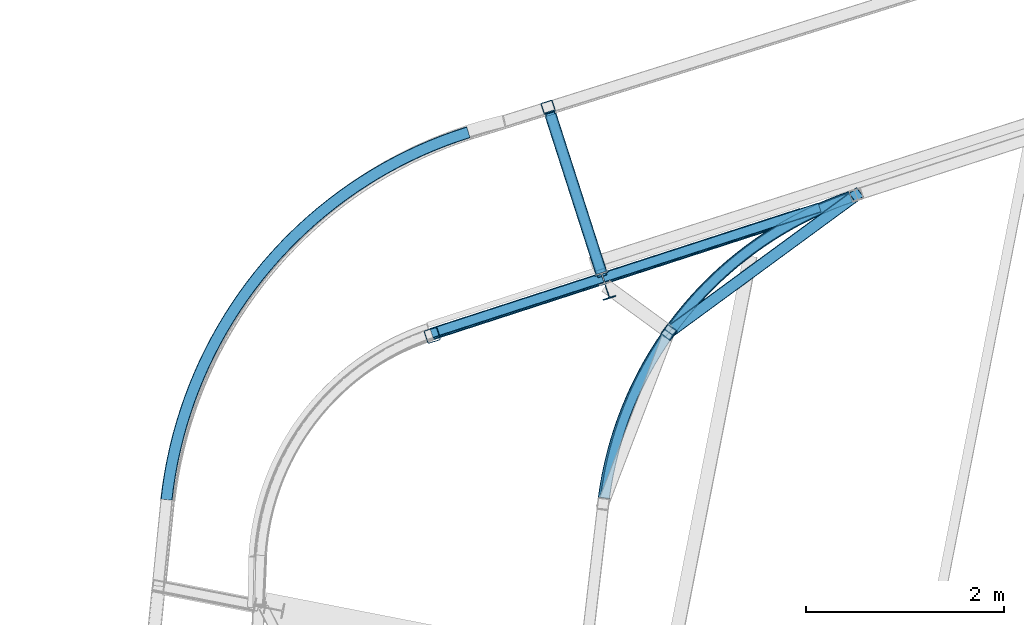
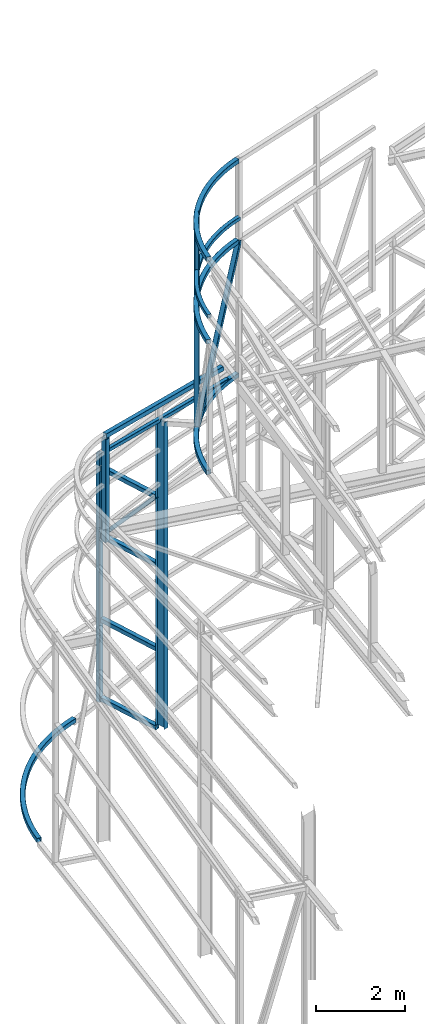
# One storey, part 79 of 215: 16 beams, 2 members, 18 elements without a shape of their own.
"""IFC2X3 building model written with IfcOpenShell, lengths in millimetres."""

from ifc_helpers import new_model, entity, si_unit, frame, origin_with_axes, origin_2d_with_axis, place, context, subcontext, project, spatial, hollow_rectangle, i_section, extrude, clip, halfspace, material, type_object, element, aggregate, save


model = new_model("IFC2X3")

# Units and contexts
model_context = context("Model", 3, precision=1e-05, world=origin_with_axes())
body_context = subcontext(model_context, "Body", "Model", "MODEL_VIEW")
ifc_project = project(units=[si_unit("LENGTHUNIT", "METRE", prefix="MILLI"), si_unit("AREAUNIT", "SQUARE_METRE"), si_unit("VOLUMEUNIT", "CUBIC_METRE"), si_unit("MASSUNIT", "GRAM", prefix="KILO"), si_unit("TIMEUNIT", "SECOND"), si_unit("PLANEANGLEUNIT", "RADIAN"), si_unit("SOLIDANGLEUNIT", "STERADIAN"), si_unit("THERMODYNAMICTEMPERATUREUNIT", "DEGREE_CELSIUS"), si_unit("LUMINOUSINTENSITYUNIT", "LUMEN")], contexts=[model_context])

# Site, building, storey
site_placement = place(None, origin_with_axes())
site = spatial("IfcSite", under=ifc_project, at=site_placement, CompositionType="ELEMENT")
building_placement = place(site_placement, origin_with_axes())
building = spatial("IfcBuilding", under=site, at=building_placement, Name="Undefined", CompositionType="ELEMENT")
storey_placement = place(building_placement, origin_with_axes())
storey = spatial("IfcBuildingStorey", under=building, at=storey_placement, Name="Undefined", CompositionType="ELEMENT", Elevation=0.0)

# Assembly, beam
assembly_1_placement = place(storey_placement, origin_with_axes())
assembly_1 = element("IfcElementAssembly", 1, at=assembly_1_placement, inside=storey, Name="Steel Assembly", AssemblyPlace="NOTDEFINED", PredefinedType="RIGID_FRAME")
ifc_material = material(Name="STEEL/S275JR")
beam_type_1 = type_object("IfcBeamType", PredefinedType="NOTDEFINED")
beam_1_placement = place(assembly_1_placement, frame((42542.7227578223, 55453.7060459712, 12589.2513155091), z_axis=(-0.770723180057462, 0.637170134047504, 0.0), x_axis=(0.637141768008562, 0.770688869010357, -0.009435817000127)))
beam_1 = element("IfcBeam", 2, at=beam_1_placement, type_object=beam_type_1, material=ifc_material, Name="LISSE", context=body_context, shape_type="SweptSolid", body=[
    entity("IfcRevolvedAreaSolid", entity("IfcRectangleHollowProfileDef", "AREA", None, entity("IfcAxis2Placement2D", entity("IfcCartesianPoint", [0.0, 0.0]), entity("IfcDirection", [1.0, 0.0])), 100.0, 100.0, 4.0, 4.0, 8.0), entity("IfcAxis2Placement3D", entity("IfcCartesianPoint", [3978.35835192623, 1.81208805191692e-12, -6.4393351700896e-12]), entity("IfcDirection", [-0.842259079716441, 1.92865784701155e-18, 0.539072947415481]), entity("IfcDirection", [-6.93889390390723e-18, -1.0, -3.46944695195361e-18])), entity("IfcAxis1Placement", entity("IfcCartesianPoint", [0.0, -3690.0, 0.0]), entity("IfcDirection", [1.0, 0.0, 0.0])), 1.13867209462348),
])
aggregate(assembly_1, [beam_1])

assembly_2_placement = place(storey_placement, origin_with_axes())
assembly_2 = element("IfcElementAssembly", 3, at=assembly_2_placement, inside=storey, Name="Steel Assembly", AssemblyPlace="NOTDEFINED", PredefinedType="RIGID_FRAME")
beam_type_2 = type_object("IfcBeamType", Name="IPE270", PredefinedType="NOTDEFINED")
beam_2_placement = place(assembly_2_placement, frame((42548.0428114001, 57609.6907890693, 8437.76919773371), z_axis=(0.308275434998926, -0.951297143996671, -1.00000033853226e-09), x_axis=(0.0, 0.0, -1.0)))
beam_2 = element("IfcBeam", 4, at=beam_2_placement, type_object=beam_type_2, material=ifc_material, Name="POTEAU", ObjectType="IPE270", context=body_context, shape_type="SweptSolid", body=[
    extrude(i_section(OverallWidth=135.0, OverallDepth=270.0, WebThickness=6.599999905, FlangeThickness=10.19999981, FilletRadius=15.0, at=origin_2d_with_axis()), frame((8437.76579462243, 7.27595761418343e-12, 0.0), z_axis=(-1.0, 0.0, 0.0), x_axis=(-6.93889390390723e-18, -1.0, -3.46944695195361e-18)), (0.0, 0.0, 1.0), 8437.8),
])
aggregate(assembly_2, [beam_2])

assembly_3_placement = place(storey_placement, origin_with_axes())
assembly_3 = element("IfcElementAssembly", 5, at=assembly_3_placement, inside=storey, Name="Steel Assembly", AssemblyPlace="NOTDEFINED", PredefinedType="RIGID_FRAME")
beam_type_3 = type_object("IfcBeamType", PredefinedType="NOTDEFINED")
beam_3_placement = place(assembly_3_placement, frame((40781.4076297939, 57116.9083149684, 8921.75667107926), z_axis=(0.310531051070919, -0.949425040216836, 0.0465033260106207), x_axis=(0.950040314278142, 0.30836609309028, -0.0483089420141436)))
beam_3 = element("IfcBeam", 6, at=beam_3_placement, type_object=beam_type_3, material=ifc_material, Name="LISSE", context=body_context, shape_type="SweptSolid", body=[
    extrude(hollow_rectangle(XDim=120.0, YDim=120.0, WallThickness=4.0, InnerFilletRadius=4.0, OuterFilletRadius=8.0, at=origin_2d_with_axis()), frame((3947.97009109409, 2.73945455979009e-14, 7.47114375156847e-12), z_axis=(-1.0, 0.0, 0.0), x_axis=(-6.93889390390723e-18, -1.0, -3.46944695195361e-18)), (0.0, 0.0, 1.0), 3948.0),
])
aggregate(assembly_3, [beam_3])

assembly_4_placement = place(storey_placement, origin_with_axes())
assembly_4 = element("IfcElementAssembly", 7, at=assembly_4_placement, inside=storey, Name="Steel Assembly", AssemblyPlace="NOTDEFINED", PredefinedType="RIGID_FRAME")
beam_4_placement = place(assembly_4_placement, frame((42531.590267057, 55463.2041690499, 14159.996982163), z_axis=(0.0, 0.0, 1.0), x_axis=(0.633842159245626, 0.773462421299731, -1.00000017161287e-09)))
beam_4 = element("IfcBeam", 8, at=beam_4_placement, type_object=beam_type_3, material=ifc_material, Name="LISSE", context=body_context, shape_type="SweptSolid", body=[
    entity("IfcRevolvedAreaSolid", entity("IfcRectangleHollowProfileDef", "AREA", None, entity("IfcAxis2Placement2D", entity("IfcCartesianPoint", [0.0, 0.0]), entity("IfcDirection", [1.0, 0.0])), 120.0, 120.0, 4.0, 4.0, 8.0), entity("IfcAxis2Placement3D", entity("IfcCartesianPoint", [3935.79399070138, 2.02811134547303e-14, -1.81898940435976e-12]), entity("IfcDirection", [-0.850375897612492, 0.526175667206066, 2.30258902810609e-25]), entity("IfcDirection", [-0.526175667206066, -0.850375897612492, 2.0883770691574e-26])), entity("IfcAxis1Placement", entity("IfcCartesianPoint", [3740.0, 0.0, 0.0]), entity("IfcDirection", [0.0, 1.0, 0.0])), 1.10819409838748),
])
aggregate(assembly_4, [beam_4])

assembly_5_placement = place(storey_placement, origin_with_axes())
assembly_5 = element("IfcElementAssembly", 9, at=assembly_5_placement, inside=storey, Name="Steel Assembly", AssemblyPlace="NOTDEFINED", PredefinedType="RIGID_FRAME")
beam_type_4 = type_object("IfcBeamType", PredefinedType="NOTDEFINED")
beam_5_placement = place(assembly_5_placement, frame((41968.4277527505, 59412.872287319, 6637.5251444641), z_axis=(0.308275434998926, -0.951297143996671, -1.00000033853226e-09), x_axis=(0.0, 0.0, -1.0)))
beam_5 = element("IfcBeam", 10, at=beam_5_placement, type_object=beam_type_4, material=ifc_material, Name="MONTANT", context=body_context, shape_type="Clipping", body=[
    clip(extrude(hollow_rectangle(XDim=120.0, YDim=120.0, WallThickness=5.0, InnerFilletRadius=5.0, OuterFilletRadius=10.0, at=origin_2d_with_axis()), frame((6827.69987177694, 0.0, -7.27595761418343e-12), z_axis=(-1.0, 0.0, 0.0), x_axis=(-6.93889390390723e-18, -1.0, -3.46944695195361e-18)), (0.0, 0.0, 1.0), 6827.7), halfspace(frame((6807.14545672149, 74.2225101954245, -53.9039358184527), z_axis=(-0.988586787798364, -0.150645981404385, -0.00139688124845566), x_axis=(-1.00281613456778e-09, -0.00927220358091447, 0.999957012196401)), True)),
])
aggregate(assembly_5, [beam_5])

assembly_6_placement = place(storey_placement, origin_with_axes())
assembly_6 = element("IfcElementAssembly", 11, at=assembly_6_placement, inside=storey, Name="Steel Assembly", AssemblyPlace="NOTDEFINED", PredefinedType="RIGID_FRAME")
beam_6_placement = place(assembly_6_placement, frame((43189.504021297, 57137.5298750017, 11964.6202825493), z_axis=(0.808746567331494, -0.588157283241077, 1.39999992882708e-08), x_axis=(0.0, 0.0, -1.0)))
beam_6 = element("IfcBeam", 12, at=beam_6_placement, type_object=beam_type_4, material=ifc_material, Name="LISSE", context=body_context, shape_type="SweptSolid", body=[
    extrude(hollow_rectangle(XDim=120.0, YDim=120.0, WallThickness=5.0, InnerFilletRadius=5.0, OuterFilletRadius=10.0, at=origin_2d_with_axis()), frame((3754.43680852719, -2.37772296272483e-20, -5.68434193577036e-12), z_axis=(-1.0, 0.0, 0.0), x_axis=(-6.93889390390723e-18, -1.0, -3.46944695195361e-18)), (0.0, 0.0, 1.0), 3754.4),
])
aggregate(assembly_6, [beam_6])

assembly_7_placement = place(storey_placement, origin_with_axes())
assembly_7 = element("IfcElementAssembly", 13, at=assembly_7_placement, inside=storey, Name="Steel Assembly", AssemblyPlace="NOTDEFINED", PredefinedType="RIGID_FRAME")
beam_7_placement = place(assembly_7_placement, frame((38111.1028944836, 55446.6552582386, -270.824844129981), z_axis=(-0.772612172890469, 0.634878279909991, 0.0), x_axis=(0.634878279909993, 0.772612172890467, 0.0)))
beam_7 = element("IfcBeam", 14, at=beam_7_placement, type_object=beam_type_4, material=ifc_material, Name="LISSE", context=body_context, shape_type="SweptSolid", body=[
    entity("IfcRevolvedAreaSolid", entity("IfcRectangleHollowProfileDef", "AREA", None, entity("IfcAxis2Placement2D", entity("IfcCartesianPoint", [0.0, 0.0]), entity("IfcDirection", [1.0, 0.0])), 120.0, 120.0, 5.0, 5.0, 10.0), entity("IfcAxis2Placement3D", entity("IfcCartesianPoint", [4806.91219644417, 4.54747350886464e-13, 0.0]), entity("IfcDirection", [-0.836815951067035, 0.0, 0.547484304834188]), entity("IfcDirection", [-6.93889390390723e-18, -1.0, -3.46944695195361e-18])), entity("IfcAxis1Placement", entity("IfcCartesianPoint", [0.0, -4390.0, 0.0]), entity("IfcDirection", [1.0, 0.0, 0.0])), 1.15871000097952),
])
aggregate(assembly_7, [beam_7])

assembly_8_placement = place(storey_placement, origin_with_axes())
assembly_8 = element("IfcElementAssembly", 15, at=assembly_8_placement, inside=storey, Name="Steel Assembly", AssemblyPlace="NOTDEFINED", PredefinedType="RIGID_FRAME")
beam_8_placement = place(assembly_8_placement, frame((41993.0897888103, 59336.7685155048, 4401.39704210717), z_axis=(-0.952118187164694, -0.305730204052883, 0.0), x_axis=(0.305730204052885, -0.952118187164693, -2.00000016516782e-09)))
beam_8 = element("IfcBeam", 16, at=beam_8_placement, type_object=beam_type_4, material=ifc_material, context=body_context, shape_type="SweptSolid", body=[
    extrude(hollow_rectangle(XDim=120.0, YDim=120.0, WallThickness=5.0, InnerFilletRadius=5.0, OuterFilletRadius=10.0, at=origin_2d_with_axis()), frame((1679.04849836447, 9.09494701772928e-13, 1.0069354480596e-29), z_axis=(-1.0, 0.0, 0.0), x_axis=(-6.93889390390723e-18, -1.0, -3.46944695195361e-18)), (0.0, 0.0, 1.0), 1679.0),
])
aggregate(assembly_8, [beam_8])

assembly_9_placement = place(storey_placement, origin_with_axes())
assembly_9 = element("IfcElementAssembly", 17, at=assembly_9_placement, inside=storey, Name="Steel Assembly", AssemblyPlace="NOTDEFINED", PredefinedType="RIGID_FRAME")
beam_9_placement = place(assembly_9_placement, frame((41993.0895842515, 59336.7684516154, -85.2365966519142), z_axis=(-0.952118187164694, -0.305730204052883, 0.0), x_axis=(0.305730204052885, -0.952118187164693, -2.00000016516782e-09)))
beam_9 = element("IfcBeam", 18, at=beam_9_placement, type_object=beam_type_4, material=ifc_material, context=body_context, shape_type="SweptSolid", body=[
    extrude(hollow_rectangle(XDim=120.0, YDim=120.0, WallThickness=5.0, InnerFilletRadius=5.0, OuterFilletRadius=10.0, at=origin_2d_with_axis()), frame((1679.04849836447, 9.09494701772928e-13, 1.0069354480596e-29), z_axis=(-1.0, 0.0, 0.0), x_axis=(-6.93889390390723e-18, -1.0, -3.46944695195361e-18)), (0.0, 0.0, 1.0), 1679.0),
])
aggregate(assembly_9, [beam_9])

assembly_10_placement = place(storey_placement, origin_with_axes())
assembly_10 = element("IfcElementAssembly", 19, at=assembly_10_placement, inside=storey, Name="Steel Assembly", AssemblyPlace="NOTDEFINED", PredefinedType="RIGID_FRAME")
beam_10_placement = place(assembly_10_placement, frame((41993.0897890781, 59336.7685155878, 2088.86955887104), z_axis=(-0.952118187164694, -0.305730204052883, 0.0), x_axis=(0.305730204052885, -0.952118187164693, -2.00000016516782e-09)))
beam_10 = element("IfcBeam", 20, at=beam_10_placement, type_object=beam_type_4, material=ifc_material, context=body_context, shape_type="SweptSolid", body=[
    extrude(hollow_rectangle(XDim=120.0, YDim=120.0, WallThickness=5.0, InnerFilletRadius=5.0, OuterFilletRadius=10.0, at=origin_2d_with_axis()), frame((1679.04849836447, 9.09494701772928e-13, 1.0069354480596e-29), z_axis=(-1.0, 0.0, 0.0), x_axis=(-6.93889390390723e-18, -1.0, -3.46944695195361e-18)), (0.0, 0.0, 1.0), 1679.0),
])
aggregate(assembly_10, [beam_10])

assembly_11_placement = place(storey_placement, origin_with_axes())
assembly_11 = element("IfcElementAssembly", 21, at=assembly_11_placement, inside=storey, Name="Steel Assembly", AssemblyPlace="NOTDEFINED", PredefinedType="RIGID_FRAME")
beam_11_placement = place(assembly_11_placement, frame((41993.0897883796, 59336.7685155233, 6266.12054499267), z_axis=(-0.952137462299148, -0.305670170096035, 0.0), x_axis=(0.305670170096038, -0.952137462299147, -2.00000026692621e-09)))
beam_11 = element("IfcBeam", 22, at=beam_11_placement, type_object=beam_type_4, material=ifc_material, context=body_context, shape_type="SweptSolid", body=[
    extrude(hollow_rectangle(XDim=120.0, YDim=120.0, WallThickness=5.0, InnerFilletRadius=5.0, OuterFilletRadius=10.0, at=origin_2d_with_axis()), frame((1679.04750343561, 6.94437771198751e-22, 1.9444260188656e-29), z_axis=(-1.0, 0.0, 0.0), x_axis=(-6.93889390390723e-18, -1.0, -3.46944695195361e-18)), (0.0, 0.0, 1.0), 1679.0),
])
aggregate(assembly_11, [beam_11])

assembly_12_placement = place(storey_placement, origin_with_axes())
assembly_12 = element("IfcElementAssembly", 23, at=assembly_12_placement, inside=storey, Name="Steel Assembly", AssemblyPlace="NOTDEFINED", PredefinedType="RIGID_FRAME")
beam_12_placement = place(assembly_12_placement, frame((45026.1723428451, 58507.3623857522, 8271.29983528686), z_axis=(0.773462458226088, -0.633842114185274, 0.0), x_axis=(-0.63383273329707, -0.773451010362508, 0.0054406590025499)))
beam_12 = element("IfcBeam", 24, at=beam_12_placement, type_object=beam_type_4, material=ifc_material, Name="LISSE", context=body_context, shape_type="SweptSolid", body=[
    entity("IfcRevolvedAreaSolid", entity("IfcRectangleHollowProfileDef", "AREA", None, entity("IfcAxis2Placement2D", entity("IfcCartesianPoint", [0.0, 0.0]), entity("IfcDirection", [1.0, 0.0])), 120.0, 120.0, 5.0, 5.0, 10.0), entity("IfcAxis2Placement3D", entity("IfcCartesianPoint", [3935.36475167601, -6.82676962126401e-15, -4.79999925475594e-12]), entity("IfcDirection", [-0.849537155628599, 1.70249119038725e-18, -0.527528787087936]), entity("IfcDirection", [-6.93889390390723e-18, -1.0, -3.46944695195361e-18])), entity("IfcAxis1Placement", entity("IfcCartesianPoint", [0.0, 3730.0, 0.0]), entity("IfcDirection", [-1.0, 0.0, 0.0])), 1.11137807204662),
])
aggregate(assembly_12, [beam_12])

assembly_13_placement = place(storey_placement, origin_with_axes())
assembly_13 = element("IfcElementAssembly", 25, at=assembly_13_placement, inside=storey, Name="Steel Assembly", AssemblyPlace="NOTDEFINED", PredefinedType="RIGID_FRAME")
beam_13_placement = place(assembly_13_placement, frame((45026.6748178415, 58508.0076505855, 11941.7713794924), z_axis=(0.77347513168868, -0.633826648744891, 0.0), x_axis=(-0.633763535404552, -0.773398112493684, -0.0141117250090079)))
beam_13 = element("IfcBeam", 26, at=beam_13_placement, type_object=beam_type_4, material=ifc_material, Name="LISSE", context=body_context, shape_type="SweptSolid", body=[
    entity("IfcRevolvedAreaSolid", entity("IfcRectangleHollowProfileDef", "AREA", None, entity("IfcAxis2Placement2D", entity("IfcCartesianPoint", [0.0, 0.0]), entity("IfcDirection", [1.0, 0.0])), 120.0, 120.0, 5.0, 5.0, 10.0), entity("IfcAxis2Placement3D", entity("IfcCartesianPoint", [3936.05663285297, -6.82796984378427e-15, -6.42655498771337e-12]), entity("IfcDirection", [-0.849479557367539, 2.38888958948017e-18, -0.527621532554017]), entity("IfcDirection", [-6.93889390390723e-18, -1.0, -3.46944695195361e-18])), entity("IfcAxis1Placement", entity("IfcCartesianPoint", [0.0, 3730.0, 0.0]), entity("IfcDirection", [-1.0, 0.0, 0.0])), 1.11159642296755),
])
aggregate(assembly_13, [beam_13])

assembly_14_placement = place(storey_placement, origin_with_axes())
assembly_14 = element("IfcElementAssembly", 27, at=assembly_14_placement, inside=storey, Name="Steel Assembly", AssemblyPlace="NOTDEFINED", PredefinedType="RIGID_FRAME")
beam_type_5 = type_object("IfcBeamType", PredefinedType="NOTDEFINED")
beam_14_placement = place(assembly_14_placement, frame((40787.3160590315, 57128.4676222861, 8474.35190233173), z_axis=(-0.308275512952539, 0.951297117853542, -4.09559999944277e-05), x_axis=(0.950438441707263, 0.307995422905136, -0.0424922109869121)))
beam_14 = element("IfcBeam", 28, at=beam_14_placement, type_object=beam_type_5, material=ifc_material, Name="LISSE", context=body_context, shape_type="SweptSolid", body=[
    extrude(hollow_rectangle(XDim=100.0, YDim=100.0, WallThickness=5.0, InnerFilletRadius=5.0, OuterFilletRadius=10.0, at=origin_2d_with_axis()), frame((4127.11797924991, 0.0, -1.44864790042408e-11), z_axis=(-1.0, 0.0, 0.0), x_axis=(-6.93889390390723e-18, -1.0, -3.46944695195361e-18)), (0.0, 0.0, 1.0), 4127.1),
])
aggregate(assembly_14, [beam_14])

# Assembly, member
assembly_15_placement = place(storey_placement, origin_with_axes())
assembly_15 = element("IfcElementAssembly", 29, at=assembly_15_placement, inside=storey, Name="Steel Assembly", AssemblyPlace="NOTDEFINED", PredefinedType="RIGID_FRAME")
member_type_1 = type_object("IfcMemberType", PredefinedType="NOTDEFINED")
member_1_placement = place(assembly_15_placement, frame((42506.7123008955, 57738.2285224735, 6286.12054163624), z_axis=(-0.952092640251624, -0.305809739080817, 8.86680000237587e-05), x_axis=(-0.20348355196818, 0.633298949900965, -0.746677228883236)))
member_1 = element("IfcMember", 30, at=member_1_placement, type_object=member_type_1, material=ifc_material, context=body_context, shape_type="SweptSolid", body=[
    extrude(hollow_rectangle(XDim=100.0, YDim=100.0, WallThickness=5.0, InnerFilletRadius=5.0, OuterFilletRadius=10.0, at=origin_2d_with_axis()), frame((2524.14755177837, -7.27595761418343e-12, -1.60198771904481e-13), z_axis=(-1.0, 0.0, 0.0), x_axis=(-6.93889390390723e-18, -1.0, -3.46944695195361e-18)), (0.0, 0.0, 1.0), 2524.1),
])
aggregate(assembly_15, [member_1])

assembly_16_placement = place(storey_placement, origin_with_axes())
assembly_16 = element("IfcElementAssembly", 31, at=assembly_16_placement, inside=storey, Name="Steel Assembly", AssemblyPlace="NOTDEFINED", PredefinedType="RIGID_FRAME")
member_type_2 = type_object("IfcMemberType", PredefinedType="NOTDEFINED")
member_2_placement = place(assembly_16_placement, frame((45082.3834893184, 58525.5704850202, 11943.8123838444), z_axis=(0.670542392285272, 0.50896087021653, -0.539751547229627), x_axis=(-0.435308272210409, -0.319209741154292, -0.841790858406884)))
member_2 = element("IfcMember", 32, at=member_2_placement, type_object=member_type_2, material=ifc_material, context=body_context, shape_type="SweptSolid", body=[
    extrude(hollow_rectangle(XDim=120.0, YDim=120.0, WallThickness=5.0, InnerFilletRadius=5.0, OuterFilletRadius=10.0, at=origin_2d_with_axis()), frame((4348.36547170612, 7.01948841754298e-12, -7.51734038749209e-12), z_axis=(-1.0, 0.0, 0.0), x_axis=(-6.93889390390723e-18, -1.0, -3.46944695195361e-18)), (0.0, 0.0, 1.0), 4348.4),
])
aggregate(assembly_16, [member_2])

# Assembly, beam
assembly_17_placement = place(storey_placement, origin_with_axes())
assembly_17 = element("IfcElementAssembly", 33, at=assembly_17_placement, inside=storey, Name="Steel Assembly", AssemblyPlace="NOTDEFINED", PredefinedType="RIGID_FRAME")
beam_type_6 = type_object("IfcBeamType", PredefinedType="NOTDEFINED")
beam_15_placement = place(assembly_17_placement, frame((40797.8066067541, 57108.7429980492, 8853.61347771837), z_axis=(0.308275434998926, -0.951297143996671, -1.00000033853226e-09), x_axis=(0.0, 0.0, -1.0)))
beam_15 = element("IfcBeam", 34, at=beam_15_placement, type_object=beam_type_6, material=ifc_material, Name="MONTANT", context=body_context, shape_type="SweptSolid", body=[
    extrude(hollow_rectangle(XDim=140.0, YDim=140.0, WallThickness=8.0, InnerFilletRadius=12.0, OuterFilletRadius=20.0, at=origin_2d_with_axis()), frame((2829.38423716042, 7.27595761418343e-12, -7.27595761418343e-12), z_axis=(-1.0, 0.0, 0.0), x_axis=(-6.93889390390723e-18, -1.0, -3.46944695195361e-18)), (0.0, 0.0, 1.0), 2829.4),
])
aggregate(assembly_17, [beam_15])

assembly_18_placement = place(storey_placement, origin_with_axes())
assembly_18 = element("IfcElementAssembly", 35, at=assembly_18_placement, inside=storey, Name="Steel Assembly", AssemblyPlace="NOTDEFINED", PredefinedType="RIGID_FRAME")
beam_type_7 = type_object("IfcBeamType", Name="HEA120", PredefinedType="NOTDEFINED")
beam_16_placement = place(assembly_18_placement, frame((43187.0778052396, 57139.2943569671, 14219.9969930314), z_axis=(0.808746567331494, -0.588157283241077, 1.39999992882708e-08), x_axis=(0.0, 0.0, -1.0)))
beam_16 = element("IfcBeam", 36, at=beam_16_placement, type_object=beam_type_7, material=ifc_material, ObjectType="HEA120", context=body_context, shape_type="SweptSolid", body=[
    extrude(i_section(OverallWidth=120.0, OverallDepth=114.0, WebThickness=5.0, FlangeThickness=8.0, FilletRadius=12.0, at=origin_2d_with_axis()), frame((2250.5246867232, -1.45519152209205e-11, -2.27373674698596e-12), z_axis=(-1.0, 0.0, 0.0), x_axis=(-6.93889390390723e-18, -1.0, -3.46944695195361e-18)), (0.0, 0.0, 1.0), 2250.5),
])
aggregate(assembly_18, [beam_16])

save(model, "model.ifc")
